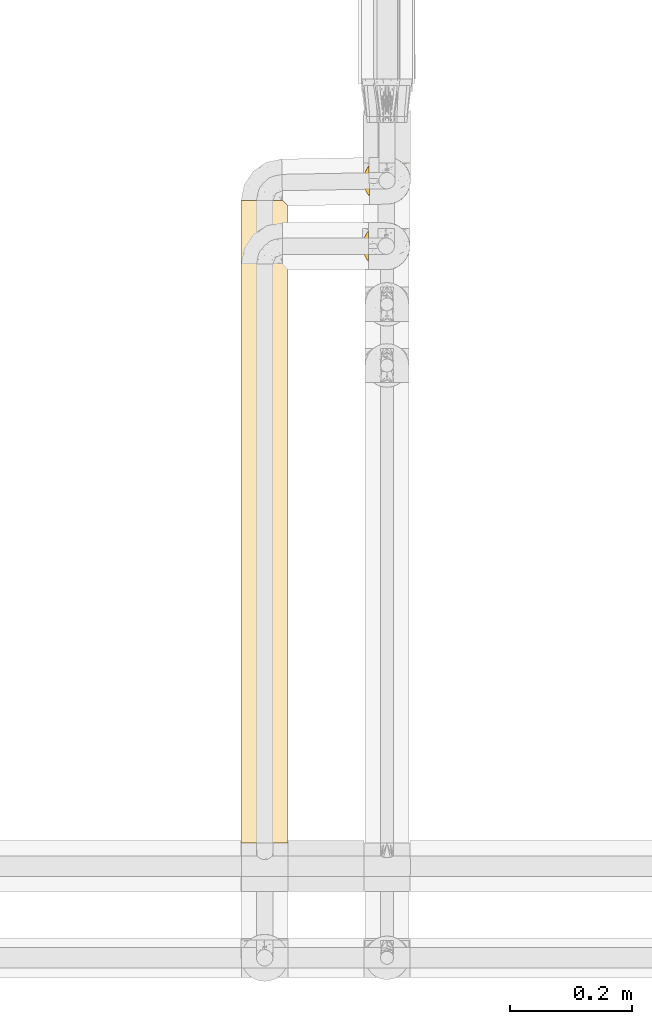
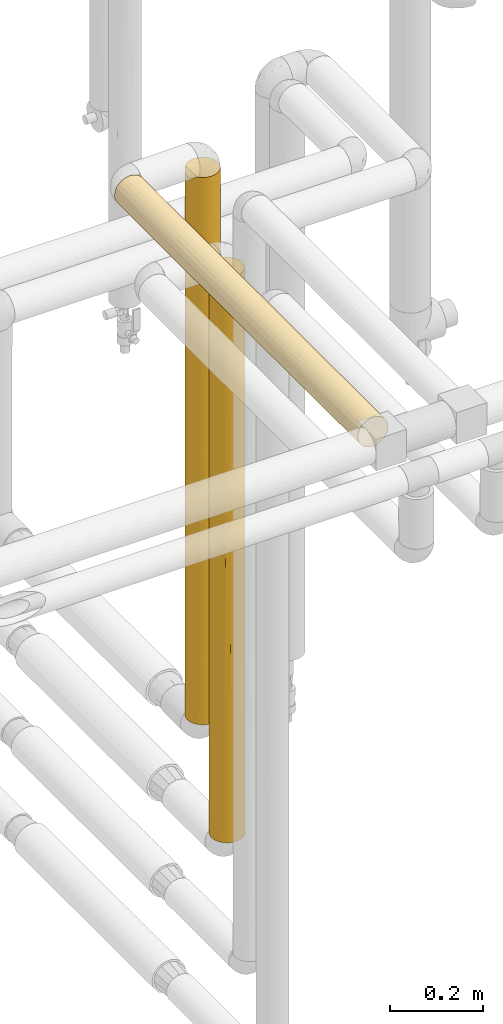
# One storey, part 27 of 827: 3 coverings.
"""IFC2X3 building model written with IfcOpenShell, lengths in millimetres."""

from ifc_helpers import new_model, entity, si_unit, converted_unit, derived_unit, direction, frame, origin, place, context, subcontext, project, spatial, faceted_brep, element, save


model = new_model("IFC2X3")

# Units and contexts
model_context = context("Model", 3, precision=0.01, world=origin(), true_north=direction((6.12303176911189e-17, 1.0)))
body_context = subcontext(model_context, "Body", "Model", "MODEL_VIEW")
ifc_project = project(units=[si_unit("LENGTHUNIT", "METRE", prefix="MILLI"), si_unit("AREAUNIT", "SQUARE_METRE"), si_unit("VOLUMEUNIT", "CUBIC_METRE"), converted_unit("PLANEANGLEUNIT", "DEGREE", entity("IfcRatioMeasure", 0.0174532925199433), si_unit("PLANEANGLEUNIT", "RADIAN"), dimensions=[0, 0, 0, 0, 0, 0, 0]), si_unit("MASSUNIT", "GRAM", prefix="KILO"), derived_unit("MASSDENSITYUNIT", [(si_unit("MASSUNIT", "GRAM", prefix="KILO"), 1), (si_unit("LENGTHUNIT", "METRE"), -3)]), derived_unit("MOMENTOFINERTIAUNIT", [(si_unit("LENGTHUNIT", "METRE"), 4)]), si_unit("TIMEUNIT", "SECOND"), si_unit("FREQUENCYUNIT", "HERTZ"), si_unit("THERMODYNAMICTEMPERATUREUNIT", "DEGREE_CELSIUS"), derived_unit("THERMALTRANSMITTANCEUNIT", [(si_unit("MASSUNIT", "GRAM", prefix="KILO"), 1), (si_unit("THERMODYNAMICTEMPERATUREUNIT", "KELVIN"), -1), (si_unit("TIMEUNIT", "SECOND"), -3)]), derived_unit("VOLUMETRICFLOWRATEUNIT", [(si_unit("LENGTHUNIT", "METRE"), 3), (si_unit("TIMEUNIT", "SECOND"), -1)]), derived_unit("MASSFLOWRATEUNIT", [(si_unit("MASSUNIT", "GRAM", prefix="KILO"), 1), (si_unit("TIMEUNIT", "SECOND"), -1)]), derived_unit("ROTATIONALFREQUENCYUNIT", [(si_unit("TIMEUNIT", "SECOND"), -1)]), si_unit("ELECTRICCURRENTUNIT", "AMPERE"), si_unit("ELECTRICVOLTAGEUNIT", "VOLT"), si_unit("POWERUNIT", "WATT"), si_unit("FORCEUNIT", "NEWTON", prefix="KILO"), si_unit("ILLUMINANCEUNIT", "LUX"), si_unit("LUMINOUSFLUXUNIT", "LUMEN"), si_unit("LUMINOUSINTENSITYUNIT", "CANDELA"), derived_unit("USERDEFINED", [(si_unit("MASSUNIT", "GRAM", prefix="KILO"), -1), (si_unit("LENGTHUNIT", "METRE"), -2), (si_unit("TIMEUNIT", "SECOND"), 3), (si_unit("LUMINOUSFLUXUNIT", "LUMEN"), 1)]), derived_unit("LINEARVELOCITYUNIT", [(si_unit("LENGTHUNIT", "METRE"), 1), (si_unit("TIMEUNIT", "SECOND"), -1)]), si_unit("PRESSUREUNIT", "PASCAL"), derived_unit("USERDEFINED", [(si_unit("LENGTHUNIT", "METRE"), -2), (si_unit("MASSUNIT", "GRAM", prefix="KILO"), 1), (si_unit("TIMEUNIT", "SECOND"), -2)]), derived_unit("LINEARFORCEUNIT", [(si_unit("MASSUNIT", "GRAM", prefix="KILO"), 1), (si_unit("LENGTHUNIT", "METRE"), 1), (si_unit("TIMEUNIT", "SECOND"), -2), (si_unit("LENGTHUNIT", "METRE"), -1)]), derived_unit("PLANARFORCEUNIT", [(si_unit("MASSUNIT", "GRAM", prefix="KILO"), 1), (si_unit("LENGTHUNIT", "METRE"), 1), (si_unit("TIMEUNIT", "SECOND"), -2), (si_unit("LENGTHUNIT", "METRE"), -2)])], contexts=[model_context])

# Site, building, storey
site_placement = place(None, origin())
site = spatial("IfcSite", under=ifc_project, at=site_placement, CompositionType="ELEMENT")
building_placement = place(site_placement, origin())
building = spatial("IfcBuilding", under=site, at=building_placement, CompositionType="ELEMENT")
storey_placement = place(building_placement, frame((0.0, 0.0, 28200.0)))
storey = spatial("IfcBuildingStorey", under=building, at=storey_placement, Name="08", CompositionType="ELEMENT", Elevation=28200.0)

# Coverings
covering_1_placement = place(storey_placement, frame((17888.53, 10823.44, 1375.75)))
element("IfcCovering", 1, at=covering_1_placement, inside=storey, Name=":ADSK_", ObjectType=":ADSK_", PredefinedType="INSULATION", context=body_context, shape_type="Brep", body=[
    faceted_brep([(77.09, 30.06, 1445.25), (78.4, 40.0, 1445.25), (77.09, 49.93, 1445.25), (73.25, 59.2, 1445.25), (67.15, 67.15, 1445.25), (59.2, 73.25, 1445.25), (49.93, 77.09, 1445.25), (40.0, 78.4, 1445.25), (31.62, 77.47, 1445.25), (23.67, 74.75, 1445.25), (16.49, 70.36, 1445.25), (10.44, 64.52, 1445.25), (11.36, 14.42, 1445.25), (17.33, 9.0, 1445.25), (24.3, 4.95, 1445.25), (31.96, 2.45, 1445.25), (40.0, 1.6, 1445.25), (49.93, 2.9, 1445.25), (59.2, 6.74, 1445.25), (67.15, 12.84, 1445.25), (73.25, 20.8, 1445.25), (77.09, 30.06, 1.6), (73.25, 20.8, 1.6), (67.15, 12.84, 1.6), (59.2, 6.74, 1.6), (49.93, 2.9, 1.6), (40.0, 1.6, 1.6), (30.06, 2.9, 1.6), (20.8, 6.74, 1.6), (12.84, 12.84, 1.6), (6.74, 20.8, 1.6), (2.9, 30.06, 1.6), (1.6, 40.0, 1.6), (2.48, 48.2, 1.6), (5.09, 56.01, 1.6), (9.31, 63.08, 1.6), (14.94, 69.1, 1.6), (65.05, 69.1, 1.6), (70.68, 63.08, 1.6), (74.9, 56.01, 1.6), (77.51, 48.2, 1.6), (78.4, 40.0, 1.6), (16.62, 9.53, 291.19), (9.53, 16.62, 255.07), (40.0, 1.6, 1228.89), (2.19, 33.27, 428.25), (1.6, 40.0, 570.47), (1.6, 40.0, 286.03), (2.95, 29.9, 226.56), (4.52, 25.3, 402.69), (30.44, 2.8, 843.1), (28.07, 3.5, 1161.15), (20.71, 6.79, 960.93), (9.71, 16.39, 1045.75), (9.22, 17.02, 1256.65), (5.6, 22.92, 1055.71), (5.55, 23.03, 201.9), (4.12, 26.31, 1438.23), (25.3, 4.52, 194.56), (1.6, 40.0, 1219.59), (2.54, 31.51, 1111.4), (2.23, 33.04, 1436.47), (1.6, 40.0, 1003.21), (20.71, 6.79, 1196.33), (14.2, 11.55, 1161.14), (3.08, 29.41, 756.31), (9.45, 16.72, 719.11), (8.87, 17.51, 486.84), (17.11, 9.16, 618.01), (32.3, 2.37, 315.2), (25.3, 4.52, 435.84), (32.05, 2.43, 547.81), (13.7, 12.02, 902.72), (40.0, 1.6, 1012.5), (6.09, 21.97, 840.81), (5.52, 23.08, 626.71), (40.0, 1.6, 579.76), (7.19, 20.03, 1441.19), (1.6, 40.0, 1435.96), (1.6, 40.0, 786.83), (40.0, 1.6, 217.96), (25.49, 4.44, 667.18), (40.0, 1.6, 796.12), (1.6, 40.0, 217.97), (40.0, 1.6, 290.68), (63.37, 9.53, 260.79), (70.46, 16.62, 325.87), (47.94, 2.43, 822.74), (47.28, 2.29, 1120.69), (53.05, 3.88, 1250.72), (75.47, 25.3, 246.65), (50.06, 2.94, 595.27), (47.16, 2.27, 384.14), (54.69, 4.52, 406.11), (78.4, 40.0, 217.97), (78.4, 40.0, 1228.88), (54.69, 4.52, 1040.74), (70.46, 16.62, 1155.65), (77.7, 32.7, 956.32), (77.25, 30.7, 1197.6), (75.47, 25.3, 1011.01), (51.57, 3.38, 212.17), (71.39, 17.89, 568.79), (66.03, 11.77, 492.11), (77.7, 32.71, 326.15), (75.47, 25.3, 531.31), (77.77, 33.12, 563.24), (76.52, 28.14, 771.16), (74.58, 23.32, 1231.39), (63.37, 9.53, 1191.78), (70.85, 17.13, 830.11), (61.63, 8.27, 957.6), (55.9, 5.04, 748.94), (60.11, 7.29, 536.66), (63.37, 9.53, 723.42), (78.4, 40.0, 434.34), (78.4, 40.0, 650.72), (78.4, 40.0, 867.09), (77.14, 49.74, 616.82), (76.41, 52.17, 287.23), (62.48, 71.13, 194.06), (59.51, 73.07, 5.57), (72.98, 59.66, 218.66), (57.23, 74.31, 603.56), (50.46, 76.94, 688.07), (56.61, 74.61, 821.95), (50.04, 77.06, 1220.66), (54.69, 75.47, 1046.26), (46.72, 77.8, 1018.6), (63.37, 70.46, 1191.78), (68.03, 66.24, 287.24), (67.73, 66.56, 544.14), (72.98, 59.66, 485.18), (75.47, 54.69, 1252.29), (77.62, 47.69, 1131.65), (75.47, 54.69, 1011.01), (77.57, 47.94, 899.03), (63.21, 70.59, 406.86), (62.77, 70.91, 717.19), (40.0, 78.4, 227.27), (48.24, 77.5, 335.45), (46.78, 77.79, 10.29), (56.68, 74.58, 384.99), (40.0, 78.4, 876.39), (40.0, 78.4, 1160.82), (70.46, 63.37, 1155.65), (53.36, 76.0, 8.5), (62.5, 71.11, 955.42), (56.88, 74.49, 1246.97), (40.0, 78.4, 443.64), (70.71, 63.04, 817.37), (40.0, 78.4, 10.9), (40.0, 78.4, 660.01), (75.62, 54.33, 789.42), (11.96, 66.24, 268.36), (27.57, 76.33, 1270.06), (19.96, 72.75, 1194.14), (3.58, 52.17, 268.35), (3.13, 50.76, 579.87), (7.01, 59.66, 437.92), (2.91, 49.96, 1133.94), (2.17, 46.61, 1436.65), (3.88, 53.03, 1438.48), (16.72, 70.53, 394.38), (17.52, 71.13, 187.65), (31.76, 77.5, 335.45), (29.53, 76.94, 688.07), (33.21, 77.79, 10.29), (26.63, 76.0, 8.5), (17.22, 70.91, 717.19), (12.2, 66.49, 534.05), (20.49, 73.08, 942.56), (23.23, 74.54, 756.51), (27.57, 76.33, 1056.92), (7.01, 59.66, 203.56), (20.48, 73.07, 5.57), (6.66, 59.06, 1441.37), (5.19, 56.22, 1241.16), (13.49, 67.78, 1235.07), (10.76, 64.89, 862.3), (8.56, 62.05, 1136.75), (2.45, 48.05, 886.32), (5.26, 56.37, 877.23), (8.0, 61.23, 667.25), (23.32, 74.58, 384.99)], [[[0, 1, 2, 3, 4, 5, 6, 7, 8, 9, 10, 11, 12, 13, 14, 15, 16, 17, 18, 19, 20]], [[21, 22, 23, 24, 25, 26, 27, 28, 29, 30, 31, 32, 33, 34, 35, 36, 37, 38, 39, 40, 41]], [[29, 42, 43]], [[44, 16, 15]], [[45, 46, 47]], [[48, 49, 45]], [[50, 51, 52]], [[53, 54, 55]], [[49, 48, 56]], [[57, 55, 54]], [[58, 42, 28]], [[59, 60, 61]], [[30, 29, 43]], [[29, 28, 42]], [[60, 59, 62]], [[63, 64, 52]], [[65, 55, 60]], [[66, 67, 68]], [[69, 70, 58]], [[67, 49, 43]], [[70, 69, 71]], [[51, 15, 14]], [[64, 72, 52]], [[12, 64, 13]], [[13, 63, 14]], [[28, 27, 58]], [[57, 61, 60]], [[51, 44, 15]], [[73, 51, 50]], [[63, 52, 51]], [[74, 65, 75]], [[76, 71, 69]], [[54, 12, 77]], [[53, 66, 72]], [[61, 78, 59]], [[65, 62, 79, 46]], [[60, 55, 57]], [[45, 65, 46]], [[65, 45, 75]], [[27, 26, 80]], [[68, 42, 70]], [[66, 75, 67]], [[52, 68, 81]], [[31, 48, 32]], [[71, 82, 50]], [[81, 70, 71]], [[72, 68, 52]], [[42, 68, 67]], [[56, 43, 49]], [[48, 47, 83, 32]], [[45, 49, 75]], [[47, 48, 45]], [[56, 31, 30]], [[31, 56, 48]], [[43, 56, 30]], [[53, 72, 64]], [[68, 72, 66]], [[64, 12, 54]], [[53, 55, 74]], [[54, 77, 57]], [[64, 54, 53]], [[69, 27, 80]], [[42, 58, 70]], [[27, 69, 58]], [[69, 80, 84, 76]], [[81, 71, 50]], [[52, 81, 50]], [[68, 70, 81]], [[51, 73, 44]], [[14, 63, 51]], [[13, 64, 63]], [[62, 65, 60]], [[74, 75, 66]], [[49, 67, 75]], [[67, 43, 42]], [[53, 74, 66]], [[65, 74, 55]], [[82, 71, 76]], [[82, 73, 50]], [[85, 23, 86]], [[87, 73, 82, 76]], [[17, 44, 88]], [[88, 89, 17]], [[86, 22, 90]], [[91, 92, 93]], [[21, 41, 94]], [[1, 0, 95]], [[87, 96, 88]], [[20, 19, 97]], [[98, 99, 100]], [[101, 24, 85]], [[86, 102, 103]], [[90, 104, 105]], [[106, 107, 105]], [[73, 88, 44]], [[108, 100, 99]], [[109, 97, 19]], [[22, 21, 90]], [[22, 86, 23]], [[97, 100, 108]], [[100, 97, 110]], [[97, 111, 110]], [[112, 96, 87]], [[101, 93, 92]], [[23, 85, 24]], [[105, 104, 106]], [[113, 85, 103]], [[19, 18, 109]], [[98, 100, 107]], [[109, 111, 97]], [[103, 85, 86]], [[25, 84, 80, 26]], [[17, 16, 44]], [[101, 85, 93]], [[89, 109, 18]], [[111, 109, 96]], [[114, 103, 102]], [[110, 102, 107]], [[94, 104, 21]], [[86, 90, 105]], [[104, 94, 115]], [[104, 115, 106]], [[21, 104, 90]], [[107, 116, 117]], [[117, 98, 107]], [[106, 116, 107]], [[110, 107, 100]], [[106, 115, 116]], [[87, 88, 73]], [[88, 96, 89]], [[113, 91, 93]], [[113, 112, 91]], [[109, 89, 96]], [[18, 17, 89]], [[117, 95, 98]], [[99, 95, 0]], [[95, 99, 98]], [[108, 0, 20]], [[0, 108, 99]], [[97, 108, 20]], [[86, 105, 102]], [[113, 103, 114]], [[107, 102, 105]], [[114, 102, 110]], [[112, 113, 114]], [[85, 113, 93]], [[112, 114, 111]], [[112, 87, 91]], [[87, 76, 91]], [[92, 76, 84]], [[76, 92, 91]], [[101, 84, 25]], [[84, 101, 92]], [[24, 101, 25]], [[112, 111, 96]], [[110, 111, 114]], [[118, 115, 119]], [[120, 37, 121]], [[122, 39, 38]], [[123, 124, 125]], [[126, 127, 128]], [[5, 4, 129]], [[119, 94, 40]], [[38, 130, 122]], [[130, 131, 132]], [[133, 3, 2]], [[134, 135, 133]], [[117, 136, 134]], [[122, 132, 119]], [[137, 138, 131]], [[139, 140, 141]], [[124, 142, 140]], [[128, 143, 144]], [[37, 130, 38]], [[133, 145, 3]], [[120, 146, 142]], [[39, 119, 40]], [[137, 120, 142]], [[147, 127, 129]], [[126, 148, 127]], [[145, 129, 4]], [[146, 141, 140]], [[135, 134, 136]], [[139, 149, 140]], [[138, 147, 150]], [[3, 145, 4]], [[118, 119, 132]], [[40, 94, 41]], [[141, 151, 139]], [[124, 149, 152, 143]], [[140, 142, 146]], [[128, 124, 143]], [[124, 128, 125]], [[2, 1, 95]], [[150, 145, 135]], [[138, 125, 147]], [[132, 150, 153]], [[136, 116, 118]], [[153, 135, 136]], [[6, 126, 7]], [[131, 150, 132]], [[145, 150, 147]], [[115, 94, 119]], [[148, 129, 127]], [[144, 7, 126]], [[128, 127, 125]], [[144, 126, 128]], [[148, 6, 5]], [[6, 148, 126]], [[129, 148, 5]], [[134, 2, 95]], [[145, 133, 135]], [[2, 134, 133]], [[117, 134, 95]], [[153, 136, 118]], [[132, 153, 118]], [[150, 135, 153]], [[137, 131, 130]], [[150, 131, 138]], [[130, 37, 120]], [[137, 142, 123]], [[120, 121, 146]], [[130, 120, 137]], [[132, 122, 130]], [[39, 122, 119]], [[149, 124, 140]], [[123, 125, 138]], [[127, 147, 125]], [[147, 129, 145]], [[137, 123, 138]], [[124, 123, 142]], [[116, 136, 117]], [[116, 115, 118]], [[154, 36, 35]], [[9, 155, 156]], [[157, 158, 159]], [[160, 161, 162]], [[163, 164, 154]], [[165, 166, 149]], [[167, 168, 165]], [[169, 163, 170]], [[10, 9, 156]], [[8, 7, 144]], [[59, 161, 160]], [[171, 172, 169]], [[144, 143, 173, 155]], [[159, 174, 157]], [[175, 164, 168]], [[162, 176, 177]], [[170, 154, 159]], [[178, 11, 10]], [[157, 46, 158]], [[149, 166, 143, 152]], [[171, 179, 178]], [[161, 59, 78]], [[163, 154, 170]], [[176, 180, 177]], [[35, 34, 174]], [[174, 154, 35]], [[180, 176, 11]], [[158, 79, 181]], [[160, 177, 182]], [[33, 157, 34]], [[183, 179, 170]], [[9, 8, 155]], [[179, 182, 180]], [[139, 151, 167]], [[165, 168, 184]], [[149, 139, 165]], [[33, 32, 83]], [[164, 175, 36]], [[33, 83, 157]], [[157, 83, 47, 46]], [[167, 165, 139]], [[165, 184, 166]], [[172, 184, 169]], [[173, 143, 166]], [[171, 156, 173]], [[178, 10, 156]], [[160, 181, 62]], [[183, 158, 182]], [[157, 174, 34]], [[154, 174, 159]], [[179, 180, 178]], [[179, 169, 170]], [[170, 159, 183]], [[163, 169, 184]], [[172, 173, 166]], [[179, 171, 169]], [[158, 183, 159]], [[182, 179, 183]], [[144, 155, 8]], [[156, 155, 173]], [[178, 156, 171]], [[11, 178, 180]], [[158, 46, 79]], [[160, 182, 181]], [[184, 168, 164]], [[154, 164, 36]], [[184, 164, 163]], [[173, 172, 171]], [[184, 172, 166]], [[160, 62, 59]], [[182, 177, 180]], [[162, 177, 160]], [[158, 181, 182]], [[62, 181, 79]], [[78, 61, 57, 77, 12, 11, 176, 162, 161]], [[175, 168, 167, 151, 141, 146, 121, 37, 36]]]),
])
covering_2_placement = place(storey_placement, frame((17688.53, 9780.8, 2810.05)))
element("IfcCovering", 2, at=covering_2_placement, inside=storey, Name=":ADSK_", ObjectType=":ADSK_", PredefinedType="INSULATION", context=body_context, shape_type="Brep", body=[
    faceted_brep([(20.8, 0.01, 6.74), (30.06, 0.01, 2.9), (40.0, 0.01, 1.6), (49.93, 0.01, 2.9), (59.2, 0.01, 6.74), (67.15, 0.01, 12.84), (73.25, 0.0, 20.8), (77.09, 0.0, 30.06), (78.4, 0.0, 40.0), (77.09, 0.0, 49.93), (73.25, 0.0, 59.2), (67.15, 0.0, 67.15), (59.2, 0.0, 73.25), (49.93, 0.0, 77.09), (40.0, 0.0, 78.4), (30.06, 0.0, 77.09), (20.8, 0.0, 73.25), (12.84, 0.0, 67.15), (6.74, 0.0, 59.2), (2.9, 0.0, 49.93), (1.6, 0.0, 40.0), (2.9, 0.0, 30.06), (6.74, 0.0, 20.8), (12.84, 0.01, 12.84), (30.06, 1050.43, 2.99), (20.8, 1050.43, 6.82), (12.84, 1050.43, 12.93), (6.74, 1050.43, 20.88), (2.9, 1050.43, 30.14), (1.6, 1050.43, 40.08), (2.9, 1050.43, 50.02), (6.74, 1050.43, 59.28), (12.84, 1050.43, 67.23), (20.8, 1050.43, 73.33), (30.06, 1050.42, 77.17), (40.0, 1050.42, 78.48), (48.2, 1050.42, 77.59), (56.01, 1050.42, 74.98), (63.09, 1050.43, 70.76), (69.1, 1050.43, 65.13), (69.09, 1050.43, 15.02), (63.08, 1050.43, 9.39), (56.01, 1050.43, 5.18), (48.2, 1050.43, 2.57), (40.0, 1050.43, 1.68), (9.53, 807.8, 16.68), (1.6, 308.84, 40.02), (2.35, 229.52, 32.43), (3.06, 725.87, 29.55), (1.6, 834.05, 40.06), (40.0, 617.68, 1.64), (32.79, 725.87, 2.33), (40.0, 834.06, 1.66), (33.1, 487.5, 2.26), (25.3, 444.72, 4.55), (6.0, 666.51, 22.2), (1.6, 617.68, 40.04), (2.3, 463.26, 32.7), (9.53, 525.22, 16.66), (16.62, 727.9, 9.59), (4.52, 322.53, 25.33), (16.62, 293.13, 9.55), (23.06, 227.32, 5.55), (25.3, 791.58, 4.58), (30.46, 249.83, 2.82), (9.53, 242.64, 16.64), (14.91, 510.52, 10.97), (40.0, 432.75, 1.63), (40.0, 308.85, 1.62), (40.0, 216.38, 1.61), (59.66, 847.65, 7.08), (52.17, 783.1, 3.64), (54.69, 310.13, 4.54), (47.04, 324.57, 2.27), (51.38, 536.33, 3.36), (59.66, 612.59, 7.06), (65.63, 730.12, 11.47), (65.44, 490.09, 11.27), (71.1, 794.48, 17.54), (77.79, 1041.89, 33.29), (78.4, 824.92, 40.06), (77.01, 734.69, 29.84), (63.37, 256.55, 9.55), (77.67, 456.41, 32.58), (75.47, 543.28, 25.33), (75.99, 1043.65, 26.71), (74.54, 734.79, 23.28), (70.46, 241.58, 16.64), (75.47, 307.85, 25.32), (70.99, 522.11, 17.37), (78.4, 608.55, 40.04), (78.4, 412.46, 40.03), (78.4, 304.28, 40.02), (73.06, 1046.53, 20.56), (77.65, 224.24, 32.5), (78.4, 216.38, 40.01), (78.4, 1041.3, 40.08), (74.63, 861.86, 56.65), (76.0, 1043.65, 53.44), (73.07, 1046.53, 59.59), (77.79, 1041.89, 46.87), (77.01, 734.76, 50.26), (75.47, 307.73, 54.71), (70.46, 241.6, 63.39), (71.1, 794.48, 62.57), (76.63, 511.75, 51.53), (77.74, 322.75, 47.08), (70.99, 522.13, 62.7), (65.64, 730.08, 68.63), (59.66, 847.63, 73.04), (74.36, 654.66, 57.19), (51.38, 536.31, 76.71), (40.0, 617.68, 78.44), (40.0, 432.75, 78.43), (40.0, 216.38, 78.41), (52.18, 783.04, 76.48), (63.37, 256.55, 70.48), (59.66, 612.54, 73.03), (47.04, 324.56, 77.77), (54.69, 310.15, 75.5), (65.44, 490.0, 68.79), (40.0, 834.05, 78.46), (40.0, 741.58, 78.45), (16.62, 807.79, 70.52), (25.3, 727.89, 75.53), (16.62, 242.63, 70.48), (9.53, 293.13, 63.4), (10.93, 510.51, 65.13), (4.52, 444.72, 54.73), (25.3, 322.53, 75.5), (22.96, 525.21, 74.45), (32.66, 587.17, 77.74), (32.96, 324.56, 77.77), (9.53, 727.9, 63.43), (2.8, 249.83, 49.55), (2.28, 725.87, 47.26), (2.22, 487.49, 46.93), (32.41, 820.9, 77.7), (5.53, 227.32, 56.95), (16.62, 525.21, 70.5), (4.52, 791.58, 54.75)], [[[0, 1, 2, 3, 4, 5, 6, 7, 8, 9, 10, 11, 12, 13, 14, 15, 16, 17, 18, 19, 20, 21, 22, 23]], [[24, 25, 26, 27, 28, 29, 30, 31, 32, 33, 34, 35, 36, 37, 38, 39, 40, 41, 42, 43, 44]], [[27, 26, 45]], [[20, 46, 47]], [[27, 48, 28]], [[48, 49, 28]], [[50, 51, 52]], [[51, 53, 54]], [[55, 27, 45]], [[48, 56, 49]], [[55, 57, 48]], [[58, 45, 59]], [[21, 60, 22]], [[61, 0, 23]], [[51, 50, 53]], [[60, 57, 55]], [[56, 57, 46]], [[54, 62, 61]], [[26, 25, 59]], [[59, 25, 63]], [[63, 25, 24]], [[54, 64, 62]], [[53, 64, 54]], [[58, 65, 60]], [[66, 54, 61]], [[22, 65, 23]], [[65, 61, 23]], [[49, 29, 28]], [[1, 64, 2]], [[59, 66, 58]], [[52, 51, 24]], [[54, 59, 63]], [[46, 57, 47]], [[59, 45, 26]], [[55, 45, 58]], [[60, 65, 22]], [[65, 58, 66]], [[24, 44, 52]], [[54, 63, 51]], [[24, 51, 63]], [[53, 50, 67, 68]], [[64, 68, 69, 2]], [[68, 64, 53]], [[62, 1, 0]], [[1, 62, 64]], [[0, 61, 62]], [[48, 57, 56]], [[47, 57, 60]], [[60, 21, 47]], [[20, 47, 21]], [[60, 55, 58]], [[27, 55, 48]], [[54, 66, 59]], [[65, 66, 61]], [[70, 71, 42]], [[72, 73, 74]], [[72, 4, 3]], [[75, 76, 77]], [[72, 74, 75]], [[76, 40, 78]], [[79, 80, 81]], [[43, 71, 52]], [[42, 71, 43]], [[5, 4, 82]], [[3, 69, 73]], [[43, 52, 44]], [[76, 75, 70]], [[81, 83, 84]], [[85, 81, 86]], [[72, 82, 4]], [[70, 42, 41]], [[6, 5, 87]], [[81, 85, 79]], [[71, 50, 52]], [[84, 86, 81]], [[6, 87, 88]], [[89, 77, 76]], [[83, 90, 91, 92]], [[88, 7, 6]], [[93, 85, 86]], [[73, 69, 68, 67]], [[93, 78, 40]], [[74, 50, 71]], [[83, 94, 88]], [[41, 40, 76]], [[75, 82, 72]], [[82, 77, 87]], [[83, 81, 90]], [[7, 94, 8]], [[71, 70, 75]], [[41, 76, 70]], [[89, 76, 78]], [[87, 77, 89]], [[82, 75, 77]], [[82, 87, 5]], [[88, 87, 89]], [[3, 2, 69]], [[67, 50, 74]], [[3, 73, 72]], [[74, 73, 67]], [[75, 74, 71]], [[94, 83, 92]], [[83, 88, 84]], [[88, 89, 84]], [[86, 89, 78]], [[94, 92, 95, 8]], [[7, 88, 94]], [[89, 86, 84]], [[86, 78, 93]], [[80, 79, 96]], [[80, 90, 81]], [[97, 98, 99]], [[100, 98, 101]], [[102, 10, 9]], [[11, 10, 103]], [[96, 100, 80]], [[99, 39, 104]], [[100, 101, 80]], [[105, 106, 91]], [[107, 104, 108]], [[109, 108, 38]], [[110, 105, 101]], [[111, 112, 113]], [[9, 8, 95]], [[13, 114, 14]], [[115, 37, 36]], [[11, 116, 12]], [[109, 115, 117]], [[113, 118, 111]], [[119, 13, 12]], [[97, 104, 110]], [[116, 117, 119]], [[39, 38, 108]], [[111, 115, 112]], [[116, 119, 12]], [[106, 9, 95]], [[110, 104, 107]], [[109, 38, 37]], [[111, 117, 115]], [[118, 13, 119]], [[107, 103, 102]], [[102, 105, 110]], [[103, 116, 11]], [[120, 107, 108]], [[115, 109, 37]], [[108, 109, 117]], [[108, 117, 120]], [[108, 104, 39]], [[117, 116, 120]], [[103, 120, 116]], [[102, 103, 10]], [[103, 107, 120]], [[13, 118, 114]], [[113, 114, 118]], [[111, 118, 119]], [[117, 111, 119]], [[36, 121, 115]], [[102, 110, 107]], [[97, 101, 98]], [[104, 97, 99]], [[101, 97, 110]], [[106, 105, 102]], [[90, 101, 105]], [[9, 106, 102]], [[91, 90, 105]], [[106, 95, 92, 91]], [[101, 90, 80]], [[121, 36, 35]], [[115, 121, 122, 112]], [[123, 124, 33]], [[125, 126, 17]], [[127, 128, 126]], [[129, 130, 125]], [[33, 124, 34]], [[113, 131, 132]], [[32, 123, 33]], [[113, 132, 114]], [[125, 17, 16]], [[16, 15, 129]], [[31, 133, 32]], [[19, 134, 20]], [[135, 56, 136]], [[130, 124, 123]], [[131, 137, 124]], [[128, 138, 126]], [[134, 138, 128]], [[126, 18, 17]], [[139, 123, 133]], [[56, 135, 49]], [[136, 134, 128]], [[140, 133, 31]], [[15, 114, 132]], [[129, 132, 131]], [[140, 31, 30]], [[135, 136, 128]], [[133, 127, 139]], [[49, 135, 30]], [[34, 137, 35]], [[128, 133, 140]], [[129, 125, 16]], [[125, 139, 127]], [[133, 123, 32]], [[123, 139, 125, 130]], [[15, 14, 114]], [[131, 113, 112, 122]], [[15, 132, 129]], [[137, 131, 122]], [[131, 124, 130]], [[30, 29, 49]], [[128, 140, 135]], [[30, 135, 140]], [[56, 46, 136]], [[46, 20, 134]], [[46, 134, 136]], [[138, 19, 18]], [[19, 138, 134]], [[18, 126, 138]], [[137, 122, 121, 35]], [[34, 124, 137]], [[131, 130, 129]], [[128, 127, 133]], [[125, 127, 126]], [[39, 99, 98, 100, 96, 79, 85, 93, 40]]]),
])
covering_3_placement = place(storey_placement, frame((17887.28, 10716.23, 1130.02)))
element("IfcCovering", 3, at=covering_3_placement, inside=storey, Name=":ADSK_", ObjectType=":ADSK_", PredefinedType="INSULATION", context=body_context, shape_type="Brep", body=[
    faceted_brep([(59.2, 6.74, 1492.61), (67.15, 12.84, 1492.61), (73.25, 20.8, 1492.61), (77.09, 30.06, 1492.61), (78.4, 40.0, 1492.61), (77.09, 49.93, 1492.61), (73.25, 59.2, 1492.61), (67.15, 67.15, 1492.61), (59.2, 73.25, 1492.61), (49.93, 77.09, 1492.61), (40.0, 78.4, 1492.61), (31.79, 77.51, 1492.61), (23.98, 74.9, 1492.61), (16.91, 70.68, 1492.61), (10.9, 65.05, 1492.61), (10.9, 14.94, 1492.61), (16.91, 9.31, 1492.61), (23.98, 5.09, 1492.61), (31.79, 2.48, 1492.61), (40.0, 1.6, 1492.61), (49.93, 2.9, 1492.61), (77.09, 30.06, 1.6), (73.25, 20.8, 1.6), (67.15, 12.84, 1.6), (59.2, 6.74, 1.6), (49.93, 2.9, 1.6), (40.0, 1.6, 1.6), (30.06, 2.9, 1.6), (20.8, 6.74, 1.6), (12.84, 12.84, 1.6), (6.74, 20.8, 1.6), (2.9, 30.06, 1.6), (1.6, 40.0, 1.6), (2.48, 48.2, 1.6), (5.09, 56.01, 1.6), (9.31, 63.08, 1.6), (14.94, 69.1, 1.6), (65.05, 69.1, 1.6), (70.68, 63.08, 1.6), (74.9, 56.01, 1.6), (77.51, 48.2, 1.6), (78.4, 40.0, 1.6), (78.4, 40.0, 434.34), (76.41, 52.17, 287.23), (77.14, 49.74, 616.82), (77.7, 47.25, 1168.05), (76.36, 52.32, 963.47), (75.47, 54.69, 1242.84), (54.69, 75.47, 1307.28), (78.4, 40.0, 217.97), (56.58, 74.63, 838.3), (62.86, 70.85, 962.68), (62.77, 70.91, 717.19), (72.98, 59.66, 218.66), (68.03, 66.24, 287.24), (48.24, 77.5, 335.45), (50.46, 76.94, 688.07), (56.68, 74.58, 384.99), (47.86, 77.58, 949.96), (71.77, 61.56, 770.51), (78.4, 40.0, 1059.86), (78.4, 40.0, 867.09), (53.36, 76.0, 8.5), (46.78, 77.79, 10.29), (72.98, 59.66, 485.18), (40.0, 78.4, 227.27), (70.46, 63.37, 1298.31), (40.0, 78.4, 1184.5), (48.03, 77.55, 1189.68), (67.73, 66.56, 544.14), (62.48, 71.13, 194.06), (63.21, 70.58, 406.86), (63.37, 70.46, 1207.5), (54.69, 75.47, 1072.07), (57.06, 74.39, 624.98), (59.51, 73.07, 5.57), (40.0, 78.4, 443.64), (78.4, 40.0, 1276.23), (40.0, 78.4, 10.9), (40.0, 78.4, 876.39), (78.4, 40.0, 650.71), (70.46, 63.37, 1055.95), (78.4, 40.0, 1179.85), (40.0, 78.4, 660.01), (31.75, 77.5, 335.45), (29.53, 76.94, 688.07), (20.33, 72.98, 1243.41), (13.75, 68.03, 1103.12), (13.75, 68.03, 1316.01), (6.44, 58.66, 693.63), (2.94, 50.08, 526.08), (2.37, 47.67, 814.77), (2.98, 50.2, 1176.72), (2.2, 46.78, 1483.91), (4.0, 53.36, 1485.71), (16.75, 70.56, 399.4), (17.52, 71.13, 190.21), (11.96, 66.24, 276.72), (7.05, 59.73, 216.02), (3.58, 52.17, 254.14), (33.21, 77.79, 10.29), (26.63, 76.0, 8.5), (5.45, 56.76, 922.31), (1.6, 40.0, 1266.93), (27.82, 76.41, 1092.49), (27.82, 76.41, 1310.21), (1.6, 40.0, 217.97), (5.6, 57.07, 1137.67), (6.92, 59.51, 1488.64), (8.88, 62.51, 1251.17), (1.6, 40.0, 617.82), (20.25, 72.93, 976.33), (10.42, 64.49, 813.97), (1.6, 40.0, 434.34), (33.06, 77.76, 947.6), (26.31, 75.87, 881.05), (7.01, 59.66, 459.16), (12.24, 66.54, 538.25), (20.48, 73.07, 5.57), (1.6, 40.0, 1483.31), (17.22, 70.91, 717.19), (23.31, 74.58, 384.99), (8.94, 62.58, 1028.53), (23.12, 74.49, 708.8), (1.6, 40.0, 834.19), (1.6, 40.0, 1050.56), (1.6, 40.0, 309.71), (9.53, 16.62, 286.7), (9.41, 16.78, 1087.35), (9.08, 17.22, 777.01), (13.43, 12.26, 950.06), (2.44, 31.96, 304.53), (2.41, 32.13, 544.25), (4.52, 25.3, 186.92), (8.86, 17.51, 1300.14), (6.92, 20.48, 1488.64), (5.41, 23.31, 1109.21), (4.52, 25.3, 422.14), (4.0, 26.63, 1485.71), (16.62, 9.53, 195.9), (2.49, 31.75, 1158.75), (2.2, 33.21, 1483.91), (13.75, 11.96, 1206.96), (27.82, 3.58, 1206.97), (40.0, 1.6, 1276.23), (3.05, 29.53, 806.14), (18.43, 8.22, 723.69), (20.33, 7.01, 1009.02), (30.25, 2.85, 877.39), (40.0, 1.6, 627.11), (40.0, 1.6, 843.49), (40.0, 1.6, 1059.86), (5.36, 23.41, 655.91), (25.3, 4.52, 251.36), (20.33, 7.01, 1275.54), (27.67, 3.63, 530.73), (9.14, 17.13, 531.52), (5.6, 22.93, 869.22), (40.0, 1.6, 434.34), (32.74, 2.29, 326.15), (40.0, 1.6, 217.97), (16.62, 9.53, 438.25), (40.0, 1.6, 314.36), (63.37, 9.53, 260.79), (70.46, 16.62, 325.87), (54.69, 4.52, 1087.29), (47.28, 2.29, 1168.05), (47.92, 2.42, 870.96), (54.69, 4.52, 426.29), (57.14, 5.63, 225.73), (51.24, 3.28, 646.97), (46.8, 2.2, 448.18), (58.42, 6.31, 619.22), (56.17, 5.17, 838.57), (76.49, 28.06, 788.49), (77.72, 32.8, 977.67), (75.47, 25.3, 1045.68), (63.37, 9.53, 1238.57), (70.46, 16.62, 1198.72), (71.41, 17.91, 567.96), (65.9, 11.65, 514.87), (75.47, 25.3, 246.65), (77.7, 32.71, 326.15), (75.47, 25.3, 531.31), (61.64, 8.27, 1003.76), (70.77, 17.03, 876.17), (77.77, 33.12, 563.24), (74.74, 23.64, 1275.68), (77.38, 31.24, 1233.89), (53.07, 3.89, 1297.96), (50.19, 2.97, 236.04), (63.37, 9.53, 768.95)], [[[0, 1, 2, 3, 4, 5, 6, 7, 8, 9, 10, 11, 12, 13, 14, 15, 16, 17, 18, 19, 20]], [[21, 22, 23, 24, 25, 26, 27, 28, 29, 30, 31, 32, 33, 34, 35, 36, 37, 38, 39, 40, 41]], [[42, 43, 44]], [[45, 46, 47]], [[48, 9, 8]], [[43, 49, 40]], [[50, 51, 52]], [[53, 39, 38]], [[54, 53, 38]], [[55, 56, 57]], [[58, 50, 56]], [[46, 44, 59]], [[60, 61, 46]], [[62, 63, 55]], [[53, 64, 43]], [[39, 43, 40]], [[65, 55, 63]], [[7, 6, 66]], [[67, 68, 58]], [[37, 54, 38]], [[54, 69, 64]], [[70, 62, 57]], [[69, 59, 64]], [[71, 70, 57]], [[48, 68, 9]], [[72, 73, 48]], [[72, 8, 7]], [[50, 52, 74]], [[70, 37, 75]], [[65, 76, 55]], [[71, 52, 69]], [[5, 47, 6]], [[44, 43, 64]], [[77, 45, 5]], [[63, 78, 65]], [[79, 58, 56]], [[55, 57, 62]], [[79, 67, 58]], [[74, 56, 50]], [[5, 4, 77]], [[44, 61, 80, 42]], [[66, 47, 81]], [[66, 72, 7]], [[81, 59, 51]], [[59, 44, 64]], [[9, 68, 10]], [[61, 44, 46]], [[49, 43, 42]], [[49, 41, 40]], [[81, 47, 46]], [[45, 77, 82, 60]], [[46, 45, 60]], [[5, 45, 47]], [[47, 66, 6]], [[72, 66, 81]], [[71, 69, 54]], [[52, 51, 59]], [[52, 59, 69]], [[46, 59, 81]], [[54, 37, 70]], [[71, 57, 74]], [[70, 75, 62]], [[54, 70, 71]], [[72, 48, 8]], [[68, 48, 73]], [[68, 73, 58]], [[68, 67, 10]], [[50, 58, 73]], [[56, 76, 83, 79]], [[64, 53, 54]], [[39, 53, 43]], [[76, 56, 55]], [[51, 73, 72]], [[73, 51, 50]], [[81, 51, 72]], [[71, 74, 52]], [[57, 56, 74]], [[76, 84, 85]], [[86, 87, 88]], [[89, 90, 91]], [[92, 93, 94]], [[95, 96, 97]], [[98, 34, 99]], [[100, 101, 84]], [[91, 92, 102]], [[13, 88, 14]], [[11, 10, 67]], [[103, 93, 92]], [[33, 99, 34]], [[67, 104, 105]], [[33, 106, 99]], [[11, 105, 12]], [[107, 108, 109]], [[90, 110, 91]], [[87, 111, 112]], [[110, 90, 113]], [[114, 85, 115]], [[111, 87, 86]], [[116, 98, 99]], [[95, 97, 117]], [[118, 96, 101]], [[97, 36, 35]], [[88, 109, 14]], [[103, 119, 93]], [[91, 102, 89]], [[94, 108, 107]], [[79, 85, 114]], [[65, 78, 100]], [[13, 12, 86]], [[14, 109, 108]], [[117, 112, 120]], [[84, 101, 121]], [[76, 65, 84]], [[90, 99, 113]], [[116, 97, 98]], [[87, 122, 109]], [[122, 102, 107]], [[117, 97, 116]], [[96, 118, 36]], [[100, 84, 65]], [[84, 121, 85]], [[123, 121, 95]], [[111, 115, 123]], [[105, 86, 12]], [[114, 67, 79]], [[111, 86, 104]], [[116, 99, 90]], [[91, 110, 124, 125]], [[92, 91, 125]], [[115, 111, 104]], [[112, 111, 120]], [[67, 105, 11]], [[86, 105, 104]], [[86, 88, 13]], [[109, 88, 87]], [[112, 89, 102]], [[120, 123, 95]], [[89, 117, 116]], [[112, 102, 122]], [[112, 122, 87]], [[107, 102, 92]], [[94, 107, 92]], [[109, 122, 107]], [[120, 95, 117]], [[121, 101, 96]], [[97, 96, 36]], [[121, 96, 95]], [[117, 89, 112]], [[90, 89, 116]], [[97, 35, 98]], [[34, 98, 35]], [[114, 115, 104]], [[123, 115, 85]], [[67, 114, 104]], [[76, 85, 79, 83]], [[121, 123, 85]], [[111, 123, 120]], [[92, 125, 103]], [[106, 33, 32]], [[99, 106, 126, 113]], [[29, 127, 30]], [[128, 129, 130]], [[126, 131, 132]], [[133, 131, 31]], [[134, 15, 135]], [[134, 136, 128]], [[127, 137, 133]], [[138, 136, 134]], [[29, 28, 139]], [[103, 140, 141]], [[133, 31, 30]], [[15, 142, 16]], [[140, 103, 125]], [[143, 144, 18]], [[140, 145, 136]], [[130, 146, 147]], [[148, 149, 150, 151]], [[132, 152, 145]], [[27, 153, 28]], [[142, 154, 16]], [[142, 130, 147]], [[154, 17, 16]], [[17, 143, 18]], [[155, 148, 146]], [[151, 143, 148]], [[152, 156, 129]], [[138, 141, 140]], [[147, 143, 154]], [[152, 129, 157]], [[155, 158, 149]], [[148, 143, 147]], [[18, 144, 19]], [[141, 119, 103]], [[110, 132, 145]], [[140, 136, 138]], [[132, 110, 113, 126]], [[157, 145, 152]], [[159, 155, 153]], [[27, 26, 160]], [[139, 153, 161]], [[139, 127, 29]], [[161, 146, 156]], [[146, 148, 147]], [[31, 131, 32]], [[149, 148, 155]], [[160, 159, 27]], [[151, 144, 143]], [[161, 153, 155]], [[159, 160, 162, 158]], [[155, 159, 158]], [[27, 159, 153]], [[153, 139, 28]], [[127, 139, 161]], [[128, 130, 142]], [[129, 156, 146]], [[129, 146, 130]], [[155, 146, 161]], [[142, 15, 134]], [[128, 136, 157]], [[134, 135, 138]], [[142, 134, 128]], [[127, 133, 30]], [[131, 133, 137]], [[131, 137, 132]], [[131, 126, 106, 32]], [[152, 132, 137]], [[145, 125, 124, 110]], [[147, 154, 142]], [[17, 154, 143]], [[125, 145, 140]], [[156, 137, 127]], [[137, 156, 152]], [[161, 156, 127]], [[128, 157, 129]], [[136, 145, 157]], [[163, 23, 164]], [[165, 166, 167]], [[20, 144, 166]], [[24, 23, 163]], [[163, 168, 169]], [[170, 171, 168]], [[21, 41, 49]], [[170, 172, 173]], [[167, 173, 165]], [[174, 175, 176]], [[177, 178, 1]], [[164, 179, 180]], [[181, 182, 183]], [[178, 184, 185]], [[186, 174, 183]], [[187, 176, 188]], [[189, 20, 166]], [[22, 21, 181]], [[22, 164, 23]], [[176, 178, 185]], [[178, 176, 187]], [[175, 188, 176]], [[2, 1, 178]], [[151, 166, 144]], [[190, 168, 171]], [[181, 164, 22]], [[183, 182, 186]], [[172, 163, 180]], [[1, 0, 177]], [[3, 188, 4]], [[177, 184, 178]], [[180, 163, 164]], [[25, 190, 26]], [[169, 168, 190]], [[189, 177, 0]], [[184, 177, 165]], [[49, 182, 21]], [[164, 181, 183]], [[191, 180, 179]], [[185, 179, 174]], [[164, 183, 179]], [[180, 191, 172]], [[182, 49, 42]], [[182, 42, 186]], [[21, 182, 181]], [[174, 80, 61]], [[61, 175, 174]], [[186, 80, 174]], [[185, 174, 176]], [[174, 179, 183]], [[191, 179, 185]], [[186, 42, 80]], [[20, 19, 144]], [[167, 166, 151]], [[166, 165, 189]], [[167, 151, 150, 149]], [[170, 168, 172]], [[177, 189, 165]], [[0, 20, 189]], [[175, 61, 60, 82]], [[188, 175, 82]], [[188, 82, 77, 4]], [[187, 3, 2]], [[3, 187, 188]], [[178, 187, 2]], [[173, 167, 170]], [[184, 173, 191]], [[167, 149, 170]], [[171, 149, 158, 162]], [[149, 171, 170]], [[190, 162, 160, 26]], [[162, 190, 171]], [[169, 25, 24]], [[172, 168, 163]], [[173, 172, 191]], [[25, 169, 190]], [[24, 163, 169]], [[173, 184, 165]], [[185, 184, 191]], [[141, 138, 135, 15, 14, 108, 94, 93, 119]], [[118, 101, 100, 78, 63, 62, 75, 37, 36]]]),
])

save(model, "model.ifc")
